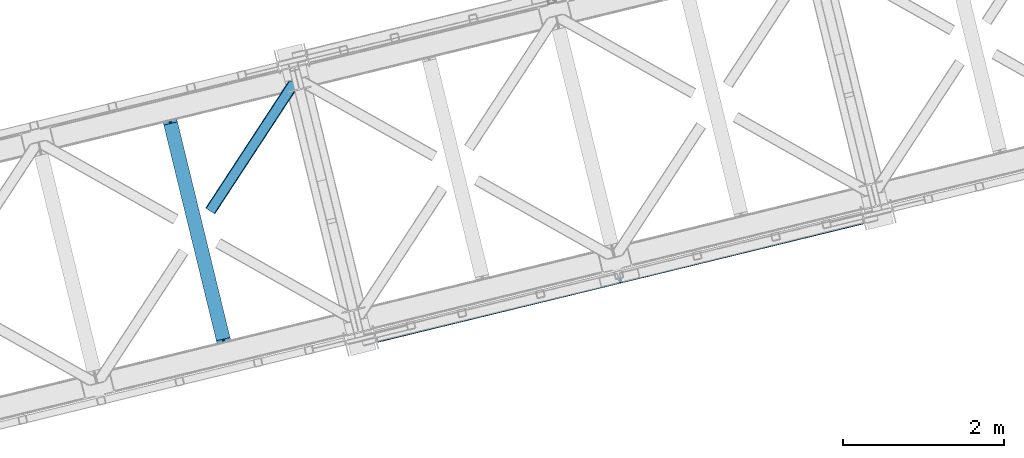
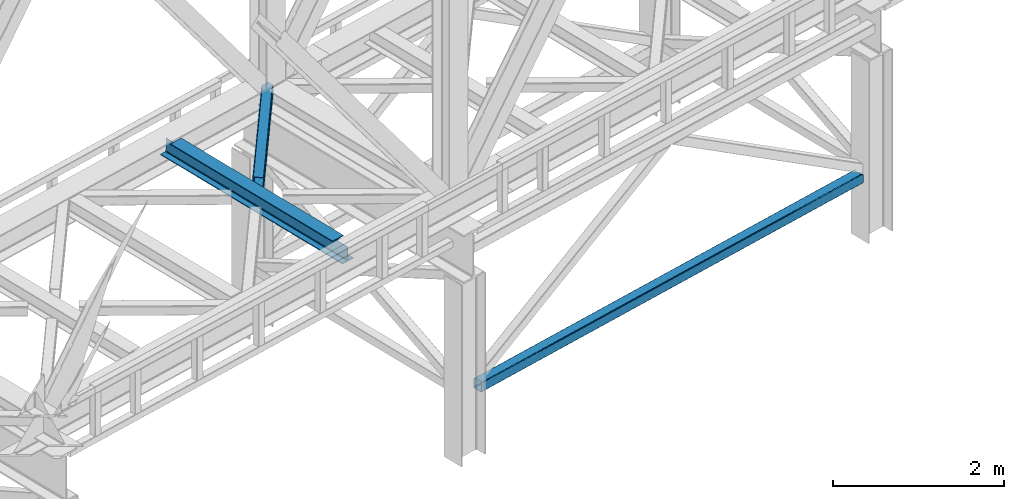
# One storey, part 43 of 93: 2 members, 1 beam.
"""IFC4 building model written with IfcOpenShell, lengths in millimetres."""

from ifc_helpers import new_model, entity, si_unit, converted_unit, derived_unit, direction, frame, origin, place, context, subcontext, project, spatial, triangles, polygons, material, type_object, element, save


model = new_model("IFC4")

# Units and contexts
model_context = context("Model", 3, precision=0.01, world=origin(), true_north=direction((6.12303176911189e-17, 1.0)))
plan_context = context("Plan", 3, precision=0.01, world=origin(), true_north=direction((6.12303176911189e-17, 1.0)))
body_context = subcontext(model_context, "Body", "Model", "MODEL_VIEW")
ifc_project = project(units=[si_unit("LENGTHUNIT", "METRE", prefix="MILLI"), si_unit("AREAUNIT", "SQUARE_METRE"), si_unit("VOLUMEUNIT", "CUBIC_METRE"), converted_unit("PLANEANGLEUNIT", "DEGREE", entity("IfcRatioMeasure", 0.0174532925199433), si_unit("PLANEANGLEUNIT", "RADIAN"), dimensions=[0, 0, 0, 0, 0, 0, 0]), si_unit("MASSUNIT", "GRAM", prefix="KILO"), derived_unit("MASSDENSITYUNIT", [(si_unit("MASSUNIT", "GRAM", prefix="KILO"), 1), (si_unit("LENGTHUNIT", "METRE"), -3)]), derived_unit("MOMENTOFINERTIAUNIT", [(si_unit("LENGTHUNIT", "METRE"), 4)]), si_unit("TIMEUNIT", "SECOND"), si_unit("FREQUENCYUNIT", "HERTZ"), si_unit("THERMODYNAMICTEMPERATUREUNIT", "DEGREE_CELSIUS"), derived_unit("THERMALTRANSMITTANCEUNIT", [(si_unit("MASSUNIT", "GRAM", prefix="KILO"), 1), (si_unit("THERMODYNAMICTEMPERATUREUNIT", "KELVIN"), -1), (si_unit("TIMEUNIT", "SECOND"), -3)]), derived_unit("VOLUMETRICFLOWRATEUNIT", [(si_unit("LENGTHUNIT", "METRE"), 3), (si_unit("TIMEUNIT", "SECOND"), -1)]), derived_unit("MASSFLOWRATEUNIT", [(si_unit("MASSUNIT", "GRAM", prefix="KILO"), 1), (si_unit("TIMEUNIT", "SECOND"), -1)]), derived_unit("ROTATIONALFREQUENCYUNIT", [(si_unit("TIMEUNIT", "SECOND"), -1)]), si_unit("ELECTRICCURRENTUNIT", "AMPERE"), si_unit("ELECTRICVOLTAGEUNIT", "VOLT"), si_unit("POWERUNIT", "WATT"), si_unit("FORCEUNIT", "NEWTON", prefix="KILO"), si_unit("ILLUMINANCEUNIT", "LUX"), si_unit("LUMINOUSFLUXUNIT", "LUMEN"), si_unit("LUMINOUSINTENSITYUNIT", "CANDELA"), derived_unit("USERDEFINED", [(si_unit("MASSUNIT", "GRAM", prefix="KILO"), -1), (si_unit("LENGTHUNIT", "METRE"), -2), (si_unit("TIMEUNIT", "SECOND"), 3), (si_unit("LUMINOUSFLUXUNIT", "LUMEN"), 1)]), derived_unit("LINEARVELOCITYUNIT", [(si_unit("LENGTHUNIT", "METRE"), 1), (si_unit("TIMEUNIT", "SECOND"), -1)]), si_unit("PRESSUREUNIT", "PASCAL"), derived_unit("USERDEFINED", [(si_unit("LENGTHUNIT", "METRE"), -2), (si_unit("MASSUNIT", "GRAM", prefix="KILO"), 1), (si_unit("TIMEUNIT", "SECOND"), -2)]), derived_unit("LINEARFORCEUNIT", [(si_unit("MASSUNIT", "GRAM", prefix="KILO"), 1), (si_unit("LENGTHUNIT", "METRE"), 1), (si_unit("TIMEUNIT", "SECOND"), -2), (si_unit("LENGTHUNIT", "METRE"), -1)]), derived_unit("PLANARFORCEUNIT", [(si_unit("MASSUNIT", "GRAM", prefix="KILO"), 1), (si_unit("LENGTHUNIT", "METRE"), 1), (si_unit("TIMEUNIT", "SECOND"), -2), (si_unit("LENGTHUNIT", "METRE"), -2)])], contexts=[model_context, plan_context])

# Site, building, storey
site_placement = place(None, origin())
site = spatial("IfcSite", under=ifc_project, at=site_placement, CompositionType="ELEMENT")
building_placement = place(site_placement, origin())
building = spatial("IfcBuilding", under=site, at=building_placement, CompositionType="ELEMENT")
storey_placement = place(building_placement, frame((0.0, 0.0, 15900.0)))
storey = spatial("IfcBuildingStorey", under=building, at=storey_placement, CompositionType="ELEMENT", Elevation=15900.0)

# Beam
ifc_material = material(Name="Metal painted (White)")
beam_type = type_object("IfcBeamType", PredefinedType="BEAM")
beam_placement = place(storey_placement, frame((-44625.4095415099, 6908.78910064206, 3441.0)))
element("IfcBeam", 1, at=beam_placement, inside=storey, type_object=beam_type, material=ifc_material, ObjectType="Steel Beam", PredefinedType="BEAM", context=body_context, shape_type="Tessellation", body=[
    polygons([(900.98534618944, 41.4445662733103, 11.000000000004), (900.985346189432, 41.4445662733103, 2.16573425859679e-12), (170.02161017477, 3040.13999372697, 2.16573425859679e-12), (170.02161017477, 3040.13999372697, 11.000000000004), (834.919806235823, 25.3403919499667, 11.000000000004), (103.956070221144, 3024.03581940363, 11.000000000004), (828.971056214522, 23.8903211957385, 12.2179274798217), (98.0073201998513, 3022.5857486494, 12.2179274798217), (823.927949458422, 22.6610105689205, 15.6862915010192), (92.9642134437427, 3021.35643802258, 15.6862915010192), (820.558253255246, 21.8396114687119, 20.8770650821657), (89.5945172405668, 3020.53503892237, 20.8770650821657), (819.37497330556, 21.5511744621217, 27.0000000000047), (88.4112372908809, 3020.24660191578, 27.0000000000047), (81.6103728838888, 3018.58881926485, 27.0000000000047), (81.6103728838888, 3018.58881926485, 203.000000000006), (88.4112372908723, 3020.24660191578, 203.000000000006), (8.66293703438714e-12, 2998.69542745366, 2.16573425859679e-12), (8.66293703438714e-12, 2998.69542745366, 10.9999999999997), (66.0655399536259, 3014.799601777, 11.000000000004), (72.0142899749184, 3016.24967253123, 12.2179274798217), (77.057396731027, 3017.47898315805, 15.6862915010192), (80.4270929342029, 3018.30038225826, 20.8770650821657), (819.374973305552, 21.5511744621195, 203.000000000006), (812.574108898559, 19.8933918111865, 203.000000000006), (812.574108898559, 19.8933918111886, 27.0000000000047), (811.390828948873, 19.6049548045963, 20.8770650821657), (808.021132745698, 18.7835557043887, 15.6862915010192), (802.978025989589, 17.5542450775696, 12.2179274798217), (797.029275968296, 16.1041743233436, 11.000000000004), (730.963736014671, -1.08286712929839e-12, 10.9999999999997), (730.963736014671, -1.08286712929839e-12, 2.16573425859679e-12), (779.675212882749, 184.415062601693, 203.069791966819), (128.020401343504, 2857.75452019162, 203.000000000006), (128.243282132658, 2856.84017775719, 203.617301946336), (128.256196377177, 2856.7871977843, 217.000003693143), (779.530009633824, 185.010597404073, 217.000003676718), (779.530880241722, 185.007025963194, 204.00000679514), (772.96491171832, 182.385463974442, 203.006342981529), (772.742064056782, 183.299815969775, 203.617301946336), (772.729149812263, 183.352795942668, 217.000003693143), (121.455336555608, 2855.1293963229, 217.000003676718), (121.454465947718, 2855.13296776378, 204.00000679514), (121.310166358664, 2855.72494066435, 203.076120467494), (121.21953693652, 2856.09673754069, 203.000000000006), (780.713494357868, 185.298194377514, 223.122939328039), (784.082490766547, 186.122464201394, 228.313710402595), (789.125126170554, 187.353708426698, 231.782072735464), (795.073705041266, 188.80448128138, 232.999999602236), (861.13915590679, 204.909021065316, 232.999999283132), (861.137682570352, 204.915065042188, 243.999994005812), (691.11630166644, 163.469558245298, 243.999994827032), (691.117775002877, 163.463514268425, 233.000000104353), (757.183225868401, 179.568054052359, 232.999999785253), (763.132130996739, 181.017488520583, 231.782072861012), (768.175695503862, 182.24492134372, 228.313710479427), (771.546082413611, 183.063487001149, 223.12293937232), (120.271851831572, 2854.84179934945, 223.122939328039), (116.902855422901, 2854.01752952557, 228.313710402595), (111.860220018886, 2852.78628530027, 231.782072735464), (105.911641148174, 2851.33551244559, 232.999999602236), (39.8461902826505, 2835.23097266165, 232.999999283128), (39.8476636190881, 2835.22492868478, 243.999994005812), (209.869044523001, 2876.67043548167, 243.999994827032), (209.867571186563, 2876.67647945855, 233.000000104357), (143.80212032104, 2860.57193967461, 232.999999785253), (137.853215192701, 2859.12250520638, 231.782072861012), (132.809650685579, 2857.89507238325, 228.313710479427), (129.439263775847, 2857.07650672582, 223.12293937232)], [[[1, 2, 3, 4]], [[5, 1, 4, 6]], [[7, 5, 6, 8]], [[9, 7, 8, 10]], [[11, 9, 10, 12]], [[13, 11, 12, 14]], [[15, 16, 17, 14, 12, 10, 8, 6, 4, 3, 18, 19, 20, 21, 22, 23]], [[13, 24, 25, 26, 27, 28, 29, 30, 31, 32, 2, 1, 5, 7, 9, 11]], [[2, 32, 18, 3]], [[32, 31, 19, 18]], [[31, 30, 20, 19]], [[27, 26, 15, 23]], [[28, 27, 23, 22]], [[29, 28, 22, 21]], [[30, 29, 21, 20]], [[33, 24, 13, 14, 17, 34, 35, 36, 37, 38]], [[25, 39, 40, 41, 42, 43, 44, 16, 15, 26]], [[39, 25, 24, 33]], [[45, 34, 17, 16]], [[41, 40, 38, 37, 46, 47, 48, 49, 50, 51, 52, 53, 54, 55, 56, 57]], [[42, 58, 59, 60, 61, 62, 63, 64, 65, 66, 67, 68, 69, 36, 35, 43]], [[46, 37, 36, 69]], [[47, 46, 69, 68]], [[48, 47, 68, 67]], [[49, 48, 67, 66]], [[50, 49, 66, 65]], [[51, 50, 65, 64]], [[52, 51, 64, 63]], [[53, 52, 63, 62]], [[54, 53, 62, 61]], [[55, 54, 61, 60]], [[56, 55, 60, 59]], [[57, 56, 59, 58]], [[41, 57, 58, 42]]], closed=False),
])

# Members
member_type_1 = type_object("IfcMemberType", PredefinedType="BRACE")
member_1_placement = place(storey_placement, frame((-41962.001858692, 7051.60735271479, 828.007590278978)))
element("IfcMember", 2, at=member_1_placement, inside=storey, type_object=member_type_1, ObjectType="Steel Vertical Brace", PredefinedType="BRACE", context=body_context, shape_type="Tessellation", body=[
    polygons([(31.1823923917571, 8.09507685196433, 17.8030399336136), (31.4978703677187, 6.80086440699542, 24.5000000000031), (6043.46200614716, 1472.28072783121, 24.5000000000031), (6043.1465281712, 1473.57494027617, 17.8030399336136), (30.2839871258991, 11.7806820741907, 12.1256313292342), (6042.24812290535, 1477.2605454984, 12.1256313292342), (28.9394286278191, 17.2965800886796, 8.3321081810543), (6040.90356440727, 1482.77644351289, 8.3321081810543), (27.3534137403818, 23.8030254244715, 7.00000000000274), (6039.31754951983, 1489.28288884868, 7.00000000000274), (31.4978703677187, 6.80086440699759, 115.500000000004), (1233.8906975236, 299.896837091837, 115.500000000004), (2436.28352467949, 592.992809776679, 115.500000000004), (3638.67635183539, 886.088782461522, 115.500000000004), (4841.06917899127, 1179.18475514637, 115.500000000004), (6043.46200614717, 1472.28072783121, 115.500000000004), (5.80223927826989, 112.214262715346, 7.00000000000274), (6017.76637505771, 1577.69412613956, 7.00000000000274), (33.1556530186517, 4.33146851719357e-12, 122.500000000002), (32.9849521637692, 0.70028080435977, 127.470710872505), (30.3790786276877, 11.3905800246047, 127.459370852399), (31.1823923917571, 8.09507685197083, 122.196960066387), (4.2162243908326, 118.720708051138, 8.3321081810543), (2.87166589275257, 124.236606065628, 12.1256313292385), (1.9732606268946, 127.922211287853, 17.8030399336136), (1.65778265093302, 129.216423732822, 24.5000000000031), (1.65778265093302, 129.216423732822, 115.500000000004), (1.9732606268946, 127.922211287853, 122.196960066391), (2.75016907863471, 124.735032899934, 127.339137700075), (0.16083565518386, 135.357478193014, 127.327869657831), (8.66293703438714e-12, 136.017288139813, 122.500000000002), (8.66293703438714e-12, 136.017288139814, 17.5000000000025), (0.315477975961585, 134.723075694843, 10.8030399336086), (1.21388324181955, 131.037470472619, 5.12563132923576), (2.55844173989092, 125.521572458127, 1.3321081810559), (4.14445662733688, 119.015127122336, 0.0), (29.0111963913235, 17.0021610174815, 4.33146851719357e-12), (30.5972112787521, 10.4957156816907, 1.3321081810559), (31.9417697768408, 4.97981766719959, 5.12563132923576), (32.8401750426901, 1.29421244497649, 10.8030399336086), (33.1556530186517, 6.49720277579036e-12, 17.5000000000025), (6042.34389731236, 1476.86764190793, 127.456289660221), (6044.94930417642, 1466.17925715645, 127.467627737819), (6045.1197887981, 1465.47986342422, 122.500000000002), (6045.1197887981, 1465.47986342422, 17.5000000000025), (6044.80431082214, 1466.77407586919, 10.8030399336086), (6043.90590555628, 1470.45968109141, 5.12563132923576), (6042.5613470582, 1475.9755791059, 1.3321081810559), (6040.97533217076, 1482.48202444169, 4.33146851719357e-12), (6016.10859240678, 1584.49499054655, 0.0), (6014.52257751935, 1591.00143588234, 1.3321081810559), (6013.17801902126, 1596.51733389683, 5.12563132923576), (6012.27961375541, 1600.20293911905, 10.8030399336086), (6011.96413577945, 1601.49715156402, 17.5000000000025), (6011.96413577944, 1601.49715156402, 122.500000000002), (6012.12476173557, 1600.83820188374, 127.324783556899), (6014.71363318048, 1590.21765180486, 127.336049676581), (6013.93739640643, 1593.40207471184, 122.196960066242), (6013.62191843038, 1594.69628715703, 115.500000000004), (6013.62191843038, 1594.69628715703, 24.5000000000031), (6013.93739640634, 1593.40207471206, 17.8030399336136), (6014.83580167219, 1589.71646948984, 12.1256313292385), (6016.18036017028, 1584.20057147535, 8.3321081810543), (6043.1465281712, 1473.57494027618, 122.196960066387), (4811.22909127449, 1301.60031447219, 115.500000000004), (3608.83626411861, 1008.50434178735, 115.500000000004), (2406.44343696271, 715.408369102506, 115.500000000004), (1204.05060980682, 422.312396417664, 115.500000000004), (3636.11791009549, 896.584498143207, 131.667891818951), (3634.53189520805, 903.090943478997, 133.000000000002), (4836.92472236395, 1196.18691616384, 133.000000000002), (4838.51073725137, 1189.68047082805, 131.667891818951), (2433.7250829396, 603.488525458366, 131.667891818951), (2432.13906805216, 609.994970794154, 133.000000000002), (1231.33225578371, 310.39255277352, 131.667891818951), (1229.74624089627, 316.898998109313, 133.000000000002), (3637.46246859358, 891.068600128714, 127.874368670766), (4839.85529574946, 1184.16457281356, 127.874368670769), (2435.06964143769, 597.972627443875, 127.874368670766), (1232.67681428179, 304.876654759037, 127.874368670764), (3638.36087385943, 887.38299490649, 122.196960066391), (4840.75370101532, 1180.47896759133, 122.196960066391), (2435.96804670354, 594.287022221649, 122.196960066391), (1233.57521954764, 301.1910495368, 122.196960066398), (31.5502884877899, 12.1280669225079, 127.832051495924), (6022.29628381583, 1481.61972718141, 132.663742407058), (6026.48870551306, 1479.26266915122, 131.667891818946), (6032.74268487119, 1477.67303378224, 130.050718215297), (6040.81788497076, 1476.91190987021, 127.874368670771), (6020.32653219421, 1484.65362745456, 133.000000000002), (45.9812256023699, 24.8297035737187, 132.663742407058), (46.3338903742774, 28.4297174134712, 133.000000000002), (43.3437470141199, 20.8077850900284, 131.667891818946), (38.5228114325978, 16.5185220342153, 130.050718215297), (4811.54456925045, 1300.30610202723, 122.196960066398), (3609.15174209456, 1007.21012934238, 122.196960066391), (2406.75891493868, 714.114156657538, 122.196960066391), (1204.36608778278, 421.018183972693, 122.196960066391), (3610.05014736042, 1003.52452412015, 127.874368670766), (4812.44297451631, 1296.62049680499, 127.874368670764), (2407.65732020453, 710.428551435313, 127.874368670766), (1205.26449304863, 417.332578750467, 127.874368670769), (3611.3947058585, 998.008626105663, 131.667891818951), (4813.78753301439, 1291.10459879051, 131.667891818951), (2409.00187870262, 704.912653420823, 131.667891818951), (1206.60905154672, 411.816680735979, 131.667891818951), (3612.98072074593, 991.502180769872, 133.000000000002), (4815.37354790183, 1284.59815345471, 133.000000000002), (2410.58789359004, 698.406208085028, 133.000000000002), (1208.19506643415, 405.310235400188, 133.000000000002), (23.1575293538741, 119.958846357108, 132.663742407058), (18.9882333015665, 122.321541507905, 131.667891818946), (12.7555666598902, 123.916372077005, 130.050718215297), (4.69904731255704, 124.682049620023, 127.874368670766), (6013.19574048155, 1589.26651108978, 127.819900969506), (5998.78345494397, 1576.58088659697, 132.663742407058), (5998.45484003982, 1572.98673516693, 133.000000000002), (6001.39780788741, 1580.59716796007, 131.667891818951), (6006.19743075267, 1584.88123581581, 130.050718215297), (25.1032311076897, 116.919083674242, 133.000000000002), (47.3930810011482, 129.557436874889, 140.000000000007), (45.4473792473327, 132.597199557755, 139.663742407063), (41.278083195025, 134.959894708553, 138.667891818953), (35.0454165533487, 136.554725277652, 137.050718215302), (26.9888972060156, 137.320402820668, 134.874368670771), (17.4181326733936, 137.227502779025, 132.222479077847), (6.70092206914705, 136.279595249225, 129.196960066394), (38.4509956920848, 2.83027378408815, 129.123005654579), (48.7045272230404, 6.82584207131562, 132.222479077849), (57.2597898737891, 11.1513529252108, 134.874368670767), (64.0789165978297, 15.5431265793589, 137.0507182153), (68.8998521793605, 19.832389635172, 138.667891818951), (71.5373307676018, 23.8543081188612, 139.663742407063), (71.8899955395179, 27.4543219586159, 140.000000000005), (6006.19810950404, 1598.53794428522, 129.117414315577), (5995.93239309075, 1594.55360519101, 132.222479077843), (5987.39246133695, 1590.23183140545, 134.874368670761), (5980.59201536491, 1585.84461138224, 137.050718215296), (5975.79239249968, 1581.5605435265, 138.667891818947), (5973.17803955624, 1577.5442621634, 139.663742407056), (5972.8494246521, 1573.95011073336, 140.000000000001), (5998.08599252255, 1472.02729414216, 140.000000000001), (6000.05574414416, 1468.99339386901, 139.663742407058), (6004.24816584138, 1466.63633583883, 138.667891818949), (6010.50214519951, 1465.04670046984, 137.050718215298), (6018.57734529909, 1464.28557655783, 134.874368670763), (6028.16344072891, 1464.38221366786, 132.222479077841), (6038.89204321754, 1465.33289809, 129.19696006639), (4813.71576525089, 1291.3990178617, 140.000000000003), (3611.322938095, 998.303045176863, 140.000000000003), (2408.93011093911, 705.207072492022, 140.000000000003), (1206.53728378322, 412.111099807177, 140.000000000003), (1231.40402354721, 310.098133702322, 140.000000000003), (2433.79685070309, 603.194106387163, 140.000000000003), (3636.18967785899, 896.290079072006, 140.000000000003), (4838.58250501488, 1189.38605175685, 140.000000000003), (3640.01865651036, 880.5821304995, 129.196960066392), (3640.33413448632, 879.287918054531, 122.500000000002), (4842.72696164221, 1172.38389073937, 122.500000000002), (4842.41148366625, 1173.67810318434, 129.19696006639), (2437.62582935447, 587.486157814659, 129.196960066392), (2437.94130733042, 586.191945369687, 122.500000000002), (1235.23300219857, 294.390185129813, 129.196960066386), (1235.54848017454, 293.095972684847, 122.500000000002), (3639.12025124451, 884.267735721724, 134.874368670767), (4841.51307840039, 1177.36370840657, 134.874368670767), (2436.72742408863, 591.171763036885, 134.874368670767), (1234.33459693272, 298.075790352039, 134.874368670767), (3637.77569274642, 889.783633736217, 138.667891818951), (4840.16851990231, 1182.87960642106, 138.667891818951), (2435.38286559054, 596.687661051376, 138.667891818951), (1232.99003843464, 303.591688366532, 138.667891818951), (3609.73692320756, 1004.80949051265, 138.667891818951), (4812.12975036345, 1297.90546319749, 138.667891818951), (2407.34409605168, 711.713517827812, 138.667891818951), (1204.95126889577, 418.617545142969, 138.667891818951), (3608.39236470948, 1010.32538852714, 134.874368670767), (4810.78519186538, 1303.42136121199, 134.874368670767), (2405.9995375536, 717.229415842302, 134.874368670767), (1203.60671039769, 424.133443157459, 134.874368670767), (3607.49395944363, 1014.01099374937, 129.196960066392), (4809.88678659952, 1307.10696643421, 129.196960066386), (2405.10113228775, 720.915021064528, 129.196960066392), (1202.70830513185, 427.819048379684, 129.19696006639), (3607.17848146767, 1015.30520619434, 122.500000000002), (4809.57130862356, 1308.40117887918, 122.500000000002), (2404.78565431178, 722.209233509496, 122.500000000002), (1202.39282715589, 429.113260824654, 122.500000000002)], [[[1, 2, 3, 4]], [[5, 1, 4, 6]], [[7, 5, 6, 8]], [[9, 7, 8, 10]], [[2, 11, 12, 13, 14, 15, 16, 3]], [[17, 9, 10, 18]], [[19, 20, 21, 22, 11, 2, 1, 5, 7, 9, 17, 23, 24, 25, 26, 27, 28, 29, 30, 31, 32, 33, 34, 35, 36, 37, 38, 39, 40, 41]], [[42, 43, 44, 45, 46, 47, 48, 49, 50, 51, 52, 53, 54, 55, 56, 57, 58, 59, 60, 61, 62, 63, 18, 10, 8, 6, 4, 3, 16, 64]], [[23, 17, 18, 63]], [[24, 23, 63, 62]], [[25, 24, 62, 61]], [[26, 25, 61, 60]], [[27, 26, 60, 59, 65, 66, 67, 68]], [[69, 70, 71, 72]], [[73, 74, 70, 69]], [[75, 76, 74, 73]], [[77, 69, 72, 78]], [[79, 73, 69, 77]], [[80, 75, 73, 79]], [[81, 77, 78, 82]], [[83, 79, 77, 81]], [[84, 80, 79, 83]], [[15, 82, 64, 16]], [[14, 81, 82, 15]], [[13, 83, 81, 14]], [[12, 84, 83, 13]], [[11, 22, 84, 12]], [[84, 85, 80]], [[72, 86, 87]], [[78, 88, 89]], [[64, 89, 42]], [[89, 64, 82, 78]], [[78, 87, 88]], [[87, 78, 72]], [[72, 90, 86]], [[90, 72, 71]], [[76, 91, 92]], [[75, 91, 76]], [[91, 75, 93]], [[75, 94, 93]], [[80, 94, 75]], [[94, 80, 85]], [[85, 22, 21]], [[85, 84, 22]], [[95, 65, 59, 58]], [[96, 66, 65, 95]], [[97, 67, 66, 96]], [[98, 68, 67, 97]], [[28, 27, 68, 98]], [[99, 96, 95, 100]], [[101, 97, 96, 99]], [[102, 98, 97, 101]], [[103, 99, 100, 104]], [[105, 101, 99, 103]], [[106, 102, 101, 105]], [[107, 103, 104, 108]], [[109, 105, 103, 107]], [[110, 106, 105, 109]], [[106, 111, 112]], [[102, 113, 114]], [[28, 114, 29]], [[95, 115, 100]], [[108, 116, 117]], [[104, 116, 108]], [[116, 104, 118]], [[104, 119, 118]], [[100, 119, 104]], [[119, 100, 115]], [[115, 58, 57]], [[115, 95, 58]], [[114, 28, 98, 102]], [[102, 112, 113]], [[112, 102, 106]], [[106, 120, 111]], [[120, 106, 110]], [[92, 120, 110, 109, 107, 108, 117, 90, 71, 70, 74, 76]], [[121, 122, 123, 124, 125, 126, 127, 30, 29, 114, 113, 112, 111, 120, 92, 91, 93, 94, 85, 21, 20, 128, 129, 130, 131, 132, 133, 134]], [[135, 136, 137, 138, 139, 140, 141, 142, 143, 144, 145, 146, 147, 148, 43, 42, 89, 88, 87, 86, 90, 117, 116, 118, 119, 115, 57, 56]], [[141, 149, 150, 151, 152, 121, 134, 153, 154, 155, 156, 142]], [[157, 158, 159, 160]], [[161, 162, 158, 157]], [[163, 164, 162, 161]], [[165, 157, 160, 166]], [[167, 161, 157, 165]], [[168, 163, 161, 167]], [[169, 165, 166, 170]], [[171, 167, 165, 169]], [[172, 168, 167, 171]], [[155, 169, 170, 156]], [[154, 171, 169, 155]], [[153, 172, 171, 154]], [[172, 133, 132]], [[168, 131, 130]], [[163, 129, 128]], [[19, 128, 20]], [[44, 148, 160, 159]], [[156, 143, 142]], [[170, 143, 156]], [[143, 170, 144]], [[170, 145, 144]], [[166, 145, 170]], [[145, 166, 146]], [[166, 147, 146]], [[160, 147, 166]], [[147, 160, 148]], [[148, 44, 43]], [[164, 128, 19]], [[128, 164, 163]], [[163, 130, 129]], [[130, 163, 168]], [[168, 132, 131]], [[132, 168, 172]], [[172, 134, 133]], [[134, 172, 153]], [[173, 150, 149, 174]], [[175, 151, 150, 173]], [[176, 152, 151, 175]], [[177, 173, 174, 178]], [[179, 175, 173, 177]], [[180, 176, 175, 179]], [[181, 177, 178, 182]], [[183, 179, 177, 181]], [[184, 180, 179, 183]], [[185, 181, 182, 186]], [[187, 183, 181, 185]], [[188, 184, 183, 187]], [[31, 127, 184, 188]], [[174, 140, 139]], [[178, 138, 137]], [[182, 136, 135]], [[55, 135, 56]], [[186, 135, 55]], [[135, 186, 182]], [[182, 137, 136]], [[137, 182, 178]], [[178, 139, 138]], [[139, 178, 174]], [[174, 141, 140]], [[141, 174, 149]], [[152, 122, 121]], [[176, 122, 152]], [[122, 176, 123]], [[176, 124, 123]], [[180, 124, 176]], [[124, 180, 125]], [[180, 126, 125]], [[184, 126, 180]], [[126, 184, 127]], [[127, 31, 30]], [[19, 41, 45, 44, 159, 158, 162, 164]], [[38, 37, 49, 48]], [[39, 38, 48, 47]], [[40, 39, 47, 46]], [[41, 40, 46, 45]], [[32, 31, 188, 187, 185, 186, 55, 54]], [[33, 32, 54, 53]], [[34, 33, 53, 52]], [[35, 34, 52, 51]], [[36, 35, 51, 50]], [[37, 36, 50, 49]]], closed=True),
])
member_type_2 = type_object("IfcMemberType", PredefinedType="BRACE")
member_2_placement = place(storey_placement, frame((-44069.1426269531, 8641.4992767334, 3511.0000579834)))
element("IfcMember", 3, at=member_2_placement, inside=storey, type_object=member_type_2, ObjectType="Steel Horizontal Brace", PredefinedType="BRACE", context=body_context, shape_type="Tessellation", body=[
    triangles([(994.771838378911, 1564.02662658691, 0.0), (1028.82092285156, 1424.34794311523, 0.0), (14.6409667968765, 67.1040435791019, 0.0), (102.486767578128, 9.58604278564417, 0.0), (1.1162109375, 75.9604797363281, 10.8028289794929), (0.0, 76.6900863647461, 17.5000946044929), (1025.02580566407, 1642.17883300781, 17.5000946044929), (4.28811035156832, 73.8821182250977, 5.12526855468968), (990.474426269531, 1585.8776184082, 9.50058288574292), (990.041894531256, 1584.44747314453, 8.74132690429906), (989.90701904297, 1583.99168701172, 8.50064392089917), (990.758129882815, 1580.48841247559, 5.12526855468968), (1027.30938720703, 1642.73461303711, 10.8702667236357), (1027.77912597657, 1642.84972229004, 9.50058288574292), (992.599877929693, 1572.93538513184, 1.33247680664135), (9.03665771484521, 70.7724243164066, 1.33247680664135), (1025.02580566407, 1642.17883300781, 122.500662231447), (0.0, 76.6900863647461, 122.500662231447), (1026.92336425782, 1642.64043273926, 129.197927856447), (1.1162109375, 75.9604797363281, 129.197927856447), (1032.31838378907, 1643.95546875, 134.874325561526), (4.28811035156832, 73.8821182250977, 134.874325561526), (1040.39230957031, 1645.92395324707, 138.667117309571), (9.03665771484521, 70.7724243164066, 138.667117309571), (1049.91730957032, 1648.24590454102, 139.999594116212), (14.6409667968765, 67.1040435791019, 139.999594116212), (994.869506835938, 1567.85081176758, 9.50058288574292), (994.75788574219, 1567.00667724609, 9.29478149414354), (994.650915527345, 1566.15091552734, 9.08781738281323), (994.539294433598, 1565.30561828613, 8.8831787109375), (994.74393310547, 1564.14522399902, 8.50064392089917), (1047.05236816406, 1647.54827270508, 9.50058288574292), (14.8921142578183, 66.9377746582031, 8.3320495605476), (20.4964233398496, 63.2693939208984, 6.99957275390625), (997.041467285162, 1554.71440429688, 6.99957275390625), (10.1435668945342, 70.0480499267578, 12.1260040283232), (1042.27126464844, 1646.38322753906, 12.1260040283232), (1036.87624511719, 1645.06702880859, 17.8035644531265), (1034.98333740234, 1644.60542907715, 24.4996673583992), (6.97166748047312, 72.1258300781246, 17.8035644531265), (5.85545654297312, 72.8554367065426, 24.4996673583992), (1026.55129394532, 1433.65900268555, 6.99957275390625), (96.6266601562529, 13.4206924438477, 6.99957275390625), (1028.71860351563, 1424.77698669434, 8.41343994140698), (1032.83463134766, 1407.88615722656, 5.12526855468968), (1033.6857421875, 1404.3817199707, 8.50064392089917), (1030.99288330079, 1415.43918457031, 1.33247680664135), (1034.98333740234, 1644.60542907715, 115.501089477541), (5.85545654297312, 72.8554367065426, 115.501089477541), (1050.3498413086, 1648.35171203613, 131.667544555665), (1059.8748413086, 1650.67250061035, 133.000021362306), (20.4964233398496, 63.2693939208984, 133.000021362306), (14.8921142578183, 66.9377746582031, 131.667544555665), (1042.27126464844, 1646.38322753906, 127.87475280762), (10.1435668945342, 70.0480499267578, 127.87475280762), (1036.87624511719, 1645.06702880859, 122.196029663086), (6.97166748047312, 72.1258300781246, 122.196029663086), (1128.10788574219, 1667.30520629883, 139.999594116212), (1128.10788574219, 1667.30520629883, 133.000021362306), (1144.33015136719, 1600.75810546875, 139.999594116212), (102.486767578128, 9.58604278564417, 139.999594116212), (1142.06052246094, 1610.07032775879, 133.000021362306), (96.6266601562529, 13.4206924438477, 133.000021362306), (1146.50211181641, 1591.84934692383, 138.667117309571), (108.08642578125, 5.91766204833948, 138.667117309571), (1148.33920898438, 1584.29631958008, 134.874325561526), (112.834973144534, 2.80738677978479, 134.874325561526), (1149.57169189453, 1579.2501159668, 129.197927856447), (116.011523437504, 0.729606628417969, 129.197927856447), (1150.00422363282, 1577.47813110351, 122.500662231447), (117.127734375004, 0.0, 122.500662231447), (1150.00422363282, 1577.47813110351, 17.5000946044929), (117.127734375004, 0.0, 17.5000946044929), (106.979516601568, 6.64203643798828, 127.87475280762), (110.156066894531, 4.56425628662146, 122.196029663086), (111.267626953129, 3.83406829833984, 115.501089477541), (102.230969238284, 9.75231170654297, 131.667544555665), (116.011523437504, 0.729606628417969, 10.8028289794929), (106.979516601568, 6.64203643798828, 12.1260040283232), (112.834973144534, 2.80738677978479, 5.12526855468968), (111.267626953129, 3.83406829833984, 24.4996673583992), (110.156066894531, 4.56425628662146, 17.8035644531265), (108.08642578125, 5.91766204833948, 1.33247680664135), (102.230969238284, 9.75231170654297, 8.3320495605476), (1147.30206298828, 1588.56233825684, 122.196029663086), (1147.73459472656, 1586.79035339356, 115.501089477541), (1146.06958007813, 1593.60854187012, 127.87475280762), (1144.23248291016, 1601.16040649414, 131.667544555665), (1147.73459472656, 1586.79035339356, 24.4996673583992), (1147.21369628907, 1588.9239440918, 17.869839477542), (1149.994921875, 1577.51650085449, 16.5001556396492), (1147.10672607422, 1589.36461486816, 16.5001556396492), (1145.27427978516, 1573.10863037109, 10.8714294433594), (1034.62056884766, 1404.788671875, 9.50058288574292), (1144.12551269532, 1572.03427734375, 9.50058288574292), (1142.79071044922, 1588.59721984863, 12.1260040283232), (1030.22548828126, 1422.8143157959, 9.50058288574292), (1029.19764404297, 1423.6724029541, 8.80643920898729), (1139.73043212891, 1590.05992126465, 9.50058288574292)], [[1, 2, 3], [4, 3, 2], [5, 6, 7], [8, 9, 10], [11, 12, 8], [5, 13, 9], [9, 8, 5], [13, 14, 9], [15, 1, 16], [3, 16, 1], [12, 15, 8], [16, 8, 15], [7, 13, 5], [17, 7, 6], [6, 18, 17], [19, 17, 20], [18, 20, 17], [21, 19, 22], [20, 22, 19], [23, 21, 24], [22, 24, 21], [25, 23, 26], [24, 26, 23], [27, 28, 9], [28, 29, 10], [29, 30, 10], [30, 31, 11], [14, 32, 27], [27, 9, 14], [33, 34, 35], [36, 33, 31], [31, 30, 36], [28, 36, 29], [28, 27, 36], [36, 30, 29], [32, 37, 27], [36, 27, 37], [35, 31, 33], [38, 39, 40], [41, 40, 39], [37, 38, 36], [40, 36, 38], [42, 35, 34], [34, 43, 42], [1, 35, 42], [31, 12, 11], [1, 31, 35], [31, 15, 12], [31, 1, 15], [2, 1, 42], [44, 2, 42], [45, 44, 46], [44, 47, 2], [44, 45, 47], [39, 48, 41], [49, 41, 48], [50, 51, 52], [52, 53, 50], [54, 50, 53], [53, 55, 54], [56, 54, 55], [55, 57, 56], [48, 56, 57], [57, 49, 48], [56, 17, 19], [50, 23, 25], [58, 51, 25], [51, 58, 59], [51, 50, 25], [54, 23, 50], [54, 56, 21], [21, 23, 54], [19, 21, 56], [39, 7, 17], [37, 14, 38], [56, 48, 17], [37, 32, 14], [39, 38, 7], [48, 39, 17], [13, 7, 38], [38, 14, 13], [60, 25, 61], [25, 60, 58], [26, 61, 25], [51, 62, 63], [51, 59, 62], [63, 52, 51], [64, 60, 61], [61, 65, 64], [66, 64, 65], [65, 67, 66], [68, 66, 67], [67, 69, 68], [70, 68, 69], [69, 71, 70], [72, 70, 71], [71, 73, 72], [69, 74, 75], [76, 73, 71], [69, 75, 71], [69, 67, 74], [75, 76, 71], [74, 67, 65], [63, 61, 26], [61, 77, 65], [77, 61, 63], [77, 74, 65], [78, 79, 80], [81, 73, 76], [73, 82, 78], [82, 73, 81], [78, 82, 79], [4, 43, 3], [83, 80, 79], [79, 84, 83], [84, 43, 4], [4, 83, 84], [55, 24, 22], [26, 52, 63], [26, 53, 52], [53, 26, 24], [55, 53, 24], [49, 18, 6], [20, 57, 55], [22, 20, 55], [57, 20, 18], [49, 57, 18], [16, 36, 8], [3, 43, 34], [34, 33, 3], [33, 36, 16], [16, 3, 33], [5, 8, 36], [6, 41, 49], [40, 6, 5], [6, 40, 41], [40, 5, 36], [85, 86, 75], [76, 75, 86], [87, 85, 74], [75, 74, 85], [88, 87, 77], [74, 77, 87], [62, 88, 63], [77, 63, 88], [86, 89, 81], [81, 76, 86], [90, 91, 92], [70, 72, 89], [72, 90, 89], [89, 86, 70], [72, 91, 90], [85, 70, 86], [68, 70, 85], [66, 85, 87], [85, 66, 68], [87, 64, 66], [88, 64, 87], [88, 62, 60], [88, 60, 64], [62, 58, 60], [62, 59, 58], [73, 78, 93], [93, 72, 73], [94, 93, 78], [94, 95, 93], [80, 45, 46], [46, 78, 80], [46, 94, 78], [47, 45, 83], [80, 83, 45], [2, 47, 4], [83, 4, 47], [93, 91, 72], [82, 81, 89], [82, 92, 96], [82, 90, 92], [84, 97, 98], [79, 96, 97], [97, 84, 79], [96, 99, 97], [43, 84, 44], [44, 42, 43], [96, 79, 82], [89, 90, 82], [96, 91, 93], [96, 92, 91], [96, 95, 99], [93, 95, 96], [99, 95, 97], [94, 97, 95]]),
])

save(model, "model.ifc")
